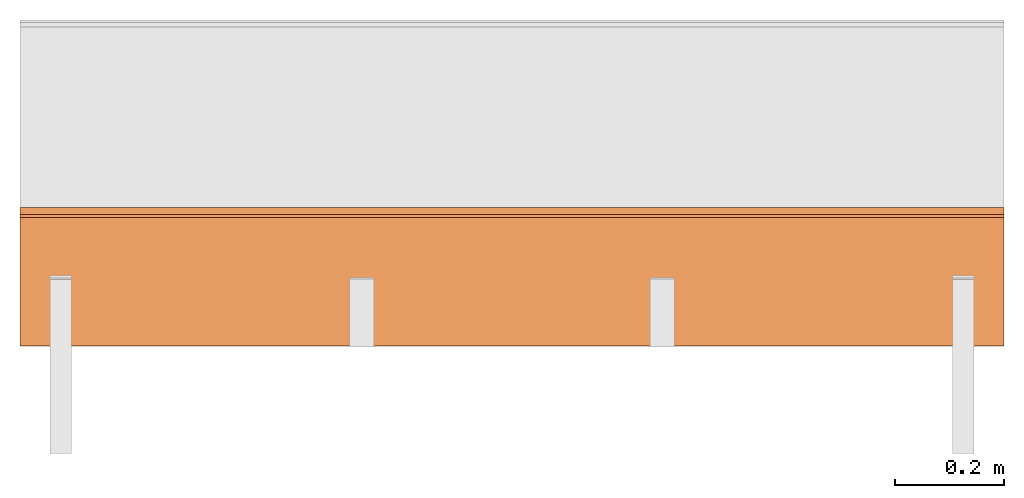
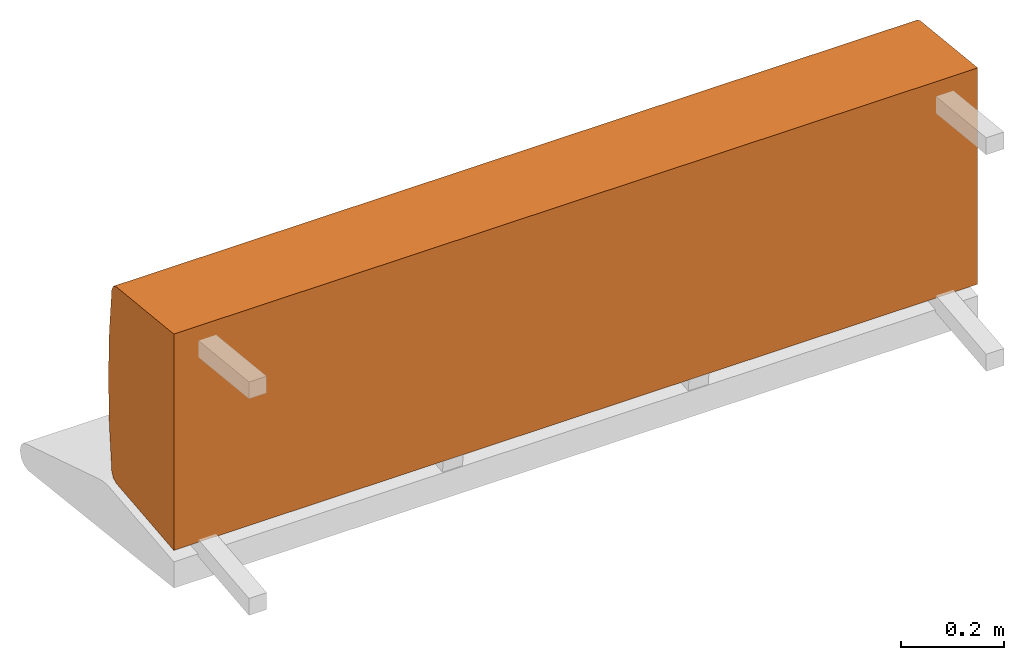
# One storey, part 1 of 3: 1 proxy, 1 element without a shape of its own.
"""IFC2X3 building model written with IfcOpenShell, lengths in metres."""

import ifcopenshell
import ifcopenshell.guid

model = None  # the IFC model being written
_history = None  # IfcOwnerHistory: only IFC2X3 demands one
_inside = {}  # id of a spatial element -> (the spatial element, [elements in it])
_under = {}  # id of a project, library or spatial element -> (it, [spatial elements below it])
_declared = {}  # id of a project -> (the project, [libraries it declares])
_typed = {}  # id of a type object -> (the type object, [elements of that type])
_made_of = {}  # id of a material, layer set ... -> (it, [elements and type objects made of it])


def new_model(schema):
    """Start an empty IFC model of exactly this schema.

    Asked for "IFC4X3", IfcOpenShell would pick the latest addendum, in which some entities
    have other attributes; the version numbers below select the first issue.
    IFC2X3 requires an IfcOwnerHistory on every rooted entity: one is made here for all.
    """
    global model, _history
    if schema == "IFC4X3":
        model = ifcopenshell.file(schema_version=(4, 3, 0, 0))
    else:
        model = ifcopenshell.file(schema=schema)
    _inside.clear()
    _under.clear()
    _declared.clear()
    _typed.clear()
    _made_of.clear()
    _history = None
    if model.schema == "IFC2X3":
        org = make("IfcOrganization", Name="unknown")
        user = make(
            "IfcPersonAndOrganization",
            ThePerson=make("IfcPerson", FamilyName="unknown"),
            TheOrganization=org,
        )
        app = make(
            "IfcApplication",
            ApplicationDeveloper=org,
            Version="unknown",
            ApplicationFullName="unknown",
            ApplicationIdentifier="unknown",
        )
        _history = make(
            "IfcOwnerHistory",
            OwningUser=user,
            OwningApplication=app,
            ChangeAction="ADDED",
            CreationDate=0,
        )
    return model


def make(cls, **values):
    """One entity of the class cls with the attributes given. An attribute that is None is left unset."""
    return model.create_entity(
        cls, **{name: value for name, value in values.items() if value is not None}
    )


def rooted(cls, **values):
    """An entity with a GlobalId (a new one), such as an element, a storey or a relation."""
    return make(cls, GlobalId=ifcopenshell.guid.new(), OwnerHistory=_history, **values)


def si_unit(unit_type, name, prefix=None):
    """IfcSIUnit, for example si_unit("LENGTHUNIT", "METRE", prefix="MILLI")."""
    return make("IfcSIUnit", UnitType=unit_type, Prefix=prefix, Name=name)


def assignment(units):
    """IfcUnitAssignment: the units of a project."""
    return None if units is None else make("IfcUnitAssignment", Units=units)


def point(xyz):
    """IfcCartesianPoint."""
    return None if xyz is None else make("IfcCartesianPoint", Coordinates=xyz)


def direction(xyz):
    """IfcDirection."""
    return None if xyz is None else make("IfcDirection", DirectionRatios=xyz)


def frame(location, z_axis=None, x_axis=None):
    """IfcAxis2Placement3D, a coordinate frame: its origin and axes. An axis left out is left unset."""
    return make(
        "IfcAxis2Placement3D",
        Location=point(location),
        Axis=direction(z_axis),
        RefDirection=direction(x_axis),
    )


def origin_with_axes():
    """The frame at (0, 0, 0) with the z axis (0, 0, 1) and the x axis (1, 0, 0) written out."""
    return frame((0.0, 0.0, 0.0), z_axis=(0.0, 0.0, 1.0), x_axis=(1.0, 0.0, 0.0))


def place(relative_to, where):
    """IfcLocalPlacement: puts the frame where relative to a parent placement (None: the world)."""
    return make(
        "IfcLocalPlacement", PlacementRelTo=relative_to, RelativePlacement=where
    )


def context(
    kind, dimensions, precision=None, world=None, true_north=None, identifier=None
):
    """IfcGeometricRepresentationContext, for example the 3D "Model" context."""
    return make(
        "IfcGeometricRepresentationContext",
        ContextIdentifier=identifier,
        ContextType=kind,
        CoordinateSpaceDimension=dimensions,
        Precision=precision,
        WorldCoordinateSystem=world,
        TrueNorth=true_north,
    )


def project(units=None, contexts=None):
    """IfcProject with its units and contexts."""
    return rooted(
        "IfcProject",
        Name="project",
        RepresentationContexts=contexts,
        UnitsInContext=assignment(units),
    )


def spatial(cls, under=None, at=None, **own):
    """A site, building, storey or space (cls), placed at a placement, below another one or the project."""
    s = rooted(cls, ObjectPlacement=at, **own)
    if under is not None:
        _under.setdefault(under.id(), (under, []))[1].append(s)
    return s


def faces_of(points, faces, orient=None, outer=None):
    """IfcFace entities. A face is a list of loops; a loop is a list of indices into points, from 0.

    orient and outer hold one flag for each loop. By default every Orientation is true, the
    first loop of a face is its IfcFaceOuterBound and the others are IfcFaceBound.
    """
    made = []
    for i, loops in enumerate(faces):
        bounds = []
        for j, loop in enumerate(loops):
            is_outer = j == 0 if outer is None else outer[i][j]
            bounds.append(
                make(
                    "IfcFaceOuterBound" if is_outer else "IfcFaceBound",
                    Bound=make("IfcPolyLoop", Polygon=[points[k] for k in loop]),
                    Orientation=True if orient is None else orient[i][j],
                )
            )
        made.append(make("IfcFace", Bounds=bounds))
    return made


def faceted_brep(points, faces, orient=None, outer=None, voids=None):
    """IfcFacetedBrep: a solid bounded by flat faces; with voids (closed shells), ...WithVoids."""
    shared = [point(p) for p in points]
    hull = make("IfcClosedShell", CfsFaces=faces_of(shared, faces, orient, outer))
    if voids is None:
        return make("IfcFacetedBrep", Outer=hull)
    return make(
        "IfcFacetedBrepWithVoids",
        Outer=hull,
        Voids=[
            make(cls, CfsFaces=faces_of(shared, fs, o, b)) for cls, fs, o, b in voids
        ],
    )


def shape(context_of_items, identifier, shape_type, items):
    """IfcShapeRepresentation: the items that make up one representation, for example the "Body"."""
    return make(
        "IfcShapeRepresentation",
        ContextOfItems=context_of_items,
        RepresentationIdentifier=identifier,
        RepresentationType=shape_type,
        Items=items,
    )


def source(mapping_origin, context_of_items, identifier, shape_type, items):
    """IfcRepresentationMap: a shape defined once, which mapped items show again and again."""
    return make(
        "IfcRepresentationMap",
        MappingOrigin=mapping_origin,
        MappedRepresentation=shape(context_of_items, identifier, shape_type, items),
    )


def transform(
    local_origin,
    x_axis=None,
    y_axis=None,
    z_axis=None,
    scale=None,
    scale2=None,
    scale3=None,
    uniform=True,
):
    """IfcCartesianTransformationOperator3D, or its non-uniform kind. x_axis, y_axis, z_axis: its Axis1, 2, 3."""
    if uniform:
        return make(
            "IfcCartesianTransformationOperator3D",
            Axis1=direction(x_axis),
            Axis2=direction(y_axis),
            LocalOrigin=point(local_origin),
            Scale=scale,
            Axis3=direction(z_axis),
        )
    return make(
        "IfcCartesianTransformationOperator3DnonUniform",
        Axis1=direction(x_axis),
        Axis2=direction(y_axis),
        LocalOrigin=point(local_origin),
        Scale=scale,
        Axis3=direction(z_axis),
        Scale2=scale2,
        Scale3=scale3,
    )


def mapped(mapping_source, mapping_target):
    """IfcMappedItem: shows the shape of a source again, moved by a transform."""
    return make(
        "IfcMappedItem", MappingSource=mapping_source, MappingTarget=mapping_target
    )


def made_of(thing, what):
    """Note that an element or type object is made of a material, layer set ...; save() writes the relation."""
    if what is not None:
        _made_of.setdefault(what.id(), (what, []))[1].append(thing)
    return thing


def element(
    cls,
    number,
    at=None,
    inside=None,
    cuts=None,
    type_object=None,
    material=None,
    context=None,
    identifier="Body",
    shape_type=None,
    held_by="IfcProductDefinitionShape",
    body=None,
    shapes=None,
    **own,
):
    """One element of the class cls, such as IfcWall. Its Tag is "e" and its number.

    at: its placement. inside: the storey or other place that contains it. cuts: it is an
    opening in that element (IfcRelVoidsElement). A single representation is given by context,
    identifier, shape_type and body (its items); several are given by shapes. held_by: the class
    of the entity that holds the representations. save() writes the other relations.
    """
    e = rooted(cls, Tag="e%d" % number, ObjectPlacement=at, **own)
    if body is not None:
        shapes = [shape(context, identifier, shape_type, body)]
    if shapes is not None:
        e.Representation = make(held_by, Representations=shapes)
    if inside is not None:
        _inside.setdefault(inside.id(), (inside, []))[1].append(e)
    if cuts is not None:
        rooted(
            "IfcRelVoidsElement", RelatingBuildingElement=cuts, RelatedOpeningElement=e
        )
    if type_object is not None:
        _typed.setdefault(type_object.id(), (type_object, []))[1].append(e)
    return made_of(e, material)


def aggregate(whole, parts):
    """IfcRelAggregates: a whole, such as a stair, and the parts it consists of."""
    return rooted("IfcRelAggregates", RelatingObject=whole, RelatedObjects=parts)


def save(model, path):
    """Write the relations noted so far, then the file.

    IfcRelAggregates (storeys below a building ...), IfcRelContainedInSpatialStructure (elements
    in a storey), IfcRelDefinesByType, IfcRelAssociatesMaterial and IfcRelDeclares: one each for
    every whole, place, type object, material and project.
    """
    for whole, parts in _under.values():
        aggregate(whole, parts)
    for where, things in _inside.values():
        rooted(
            "IfcRelContainedInSpatialStructure",
            RelatedElements=things,
            RelatingStructure=where,
        )
    for kind, things in _typed.values():
        rooted("IfcRelDefinesByType", RelatedObjects=things, RelatingType=kind)
    for what, things in _made_of.values():
        rooted("IfcRelAssociatesMaterial", RelatedObjects=things, RelatingMaterial=what)
    for by, libraries in _declared.values():
        rooted("IfcRelDeclares", RelatingContext=by, RelatedDefinitions=libraries)
    model.write(path)


model = new_model("IFC2X3")

# Units and contexts
model_context = context("Model", 3, precision=1e-06, world=origin_with_axes(), true_north=direction((0.0, 1.0, 0.0)))
ifc_project = project(units=[si_unit("LENGTHUNIT", "METRE"), si_unit("AREAUNIT", "SQUARE_METRE"), si_unit("VOLUMEUNIT", "CUBIC_METRE")], contexts=[model_context])

# Site, building, storey
site_placement = place(None, origin_with_axes())
site = spatial("IfcSite", under=ifc_project, at=site_placement, CompositionType="ELEMENT")
building_placement = place(site_placement, origin_with_axes())
building = spatial("IfcBuilding", under=site, at=building_placement, Name="Default Building", CompositionType="ELEMENT")
storey_placement = place(building_placement, origin_with_axes())
storey = spatial("IfcBuildingStorey", under=building, at=storey_placement, Name="Default Storey", CompositionType="ELEMENT", Elevation=0.0)

# Assembly, proxy
assembly_placement = place(storey_placement, origin_with_axes())
assembly = element("IfcElementAssembly", 1, at=assembly_placement, inside=storey, AssemblyPlace="NOTDEFINED", PredefinedType="NOTDEFINED")
shared_shape = source(origin_with_axes(), model_context, "Body", "Brep", [
    faceted_brep([(0.9049999713897705, -0.11101193726062775, -0.2574460208415985), (0.9049999713897705, -0.11100000143051147, 0.25755399465560913), (-0.9049999713897705, -0.11101193726062775, -0.2574460208415985), (-0.9049999713897705, -0.11101193726062775, -0.2574460208415985), (0.9049999713897705, -0.11100000143051147, 0.25755399465560913), (-0.9049999713897705, -0.11100000143051147, 0.25755399465560913), (0.9049999713897705, 0.11315424740314484, -0.23389045894145966), (0.9049999713897705, -0.11101193726062775, -0.2574460208415985), (-0.9049999713897705, 0.11315424740314484, -0.23389045894145966), (-0.9049999713897705, 0.11315424740314484, -0.23389045894145966), (0.9049999713897705, -0.11101193726062775, -0.2574460208415985), (-0.9049999713897705, -0.11101193726062775, -0.2574460208415985), (0.9049999713897705, 0.12509645521640778, -0.22825108468532562), (0.9049999713897705, 0.11315424740314484, -0.23389045894145966), (-0.9049999713897705, 0.12509645521640778, -0.22825108468532562), (-0.9049999713897705, 0.12509645521640778, -0.22825108468532562), (0.9049999713897705, 0.11315424740314484, -0.23389045894145966), (-0.9049999713897705, 0.11315424740314484, -0.23389045894145966), (0.9049999713897705, 0.1309199035167694, -0.21639753878116608), (0.9049999713897705, 0.12509645521640778, -0.22825108468532562), (-0.9049999713897705, 0.1309199035167694, -0.21639753878116608), (-0.9049999713897705, 0.1309199035167694, -0.21639753878116608), (0.9049999713897705, 0.12509645521640778, -0.22825108468532562), (-0.9049999713897705, 0.12509645521640778, -0.22825108468532562), (0.9049999713897705, 0.1406860649585724, -0.10837232321500778), (0.9049999713897705, 0.1309199035167694, -0.21639753878116608), (-0.9049999713897705, 0.1406860649585724, -0.10837232321500778), (-0.9049999713897705, 0.1406860649585724, -0.10837232321500778), (0.9049999713897705, 0.1309199035167694, -0.21639753878116608), (-0.9049999713897705, 0.1309199035167694, -0.21639753878116608), (0.9049999713897705, 0.1439555585384369, 4.417426316649653e-05), (0.9049999713897705, 0.1406860649585724, -0.10837232321500778), (-0.9049999713897705, 0.1439555585384369, 4.417426316649653e-05), (-0.9049999713897705, 0.1439555585384369, 4.417426316649653e-05), (0.9049999713897705, 0.1406860649585724, -0.10837232321500778), (-0.9049999713897705, 0.1406860649585724, -0.10837232321500778), (0.9049999713897705, 0.14071664214134216, 0.10846158862113953), (0.9049999713897705, 0.1439555585384369, 4.417426316649653e-05), (-0.9049999713897705, 0.14071664214134216, 0.10846158862113953), (-0.9049999713897705, 0.14071664214134216, 0.10846158862113953), (0.9049999713897705, 0.1439555585384369, 4.417426316649653e-05), (-0.9049999713897705, 0.1439555585384369, 4.417426316649653e-05), (0.9049999713897705, 0.1309809684753418, 0.21648956835269928), (0.9049999713897705, 0.14071664214134216, 0.10846158862113953), (-0.9049999713897705, 0.1309809684753418, 0.21648956835269928), (-0.9049999713897705, 0.1309809684753418, 0.21648956835269928), (0.9049999713897705, 0.14071664214134216, 0.10846158862113953), (-0.9049999713897705, 0.14071664214134216, 0.10846158862113953), (0.9049999713897705, 0.12515902519226074, 0.2283465564250946), (0.9049999713897705, 0.1309809684753418, 0.21648956835269928), (-0.9049999713897705, 0.12515902519226074, 0.2283465564250946), (-0.9049999713897705, 0.12515902519226074, 0.2283465564250946), (0.9049999713897705, 0.1309809684753418, 0.21648956835269928), (-0.9049999713897705, 0.1309809684753418, 0.21648956835269928), (0.9049999713897705, 0.11321509629487991, 0.23398803174495697), (0.9049999713897705, 0.12515902519226074, 0.2283465564250946), (-0.9049999713897705, 0.11321509629487991, 0.23398803174495697), (-0.9049999713897705, 0.11321509629487991, 0.23398803174495697), (0.9049999713897705, 0.12515902519226074, 0.2283465564250946), (-0.9049999713897705, 0.12515902519226074, 0.2283465564250946), (0.9049999713897705, -0.11100000143051147, 0.25755399465560913), (0.9049999713897705, 0.11321509629487991, 0.23398803174495697), (-0.9049999713897705, -0.11100000143051147, 0.25755399465560913), (-0.9049999713897705, -0.11100000143051147, 0.25755399465560913), (0.9049999713897705, 0.11321509629487991, 0.23398803174495697), (-0.9049999713897705, 0.11321509629487991, 0.23398803174495697), (0.9049999713897705, 0.1309809684753418, 0.21648956835269928), (0.9049999713897705, 0.12515902519226074, 0.2283465564250946), (0.9049999713897705, 0.14071664214134216, 0.10846158862113953), (0.9049999713897705, 0.14071664214134216, 0.10846158862113953), (0.9049999713897705, 0.12515902519226074, 0.2283465564250946), (0.9049999713897705, 0.11321509629487991, 0.23398803174495697), (0.9049999713897705, 0.14071664214134216, 0.10846158862113953), (0.9049999713897705, 0.11321509629487991, 0.23398803174495697), (0.9049999713897705, -0.11100000143051147, 0.25755399465560913), (0.9049999713897705, 0.12509645521640778, -0.22825108468532562), (0.9049999713897705, 0.1309199035167694, -0.21639753878116608), (0.9049999713897705, 0.11315424740314484, -0.23389045894145966), (0.9049999713897705, 0.11315424740314484, -0.23389045894145966), (0.9049999713897705, 0.1309199035167694, -0.21639753878116608), (0.9049999713897705, 0.1406860649585724, -0.10837232321500778), (0.9049999713897705, 0.11315424740314484, -0.23389045894145966), (0.9049999713897705, 0.1406860649585724, -0.10837232321500778), (0.9049999713897705, -0.11101193726062775, -0.2574460208415985), (0.9049999713897705, -0.11101193726062775, -0.2574460208415985), (0.9049999713897705, 0.1406860649585724, -0.10837232321500778), (0.9049999713897705, -0.11100000143051147, 0.25755399465560913), (0.9049999713897705, -0.11100000143051147, 0.25755399465560913), (0.9049999713897705, 0.1406860649585724, -0.10837232321500778), (0.9049999713897705, 0.1439555585384369, 4.417426316649653e-05), (0.9049999713897705, -0.11100000143051147, 0.25755399465560913), (0.9049999713897705, 0.1439555585384369, 4.417426316649653e-05), (0.9049999713897705, 0.14071664214134216, 0.10846158862113953), (-0.9049999713897705, 0.1406860649585724, -0.10837232321500778), (-0.9049999713897705, 0.1309199035167694, -0.21639753878116608), (-0.9049999713897705, 0.12509645521640778, -0.22825108468532562), (-0.9049999713897705, 0.12515902519226074, 0.2283465564250946), (-0.9049999713897705, 0.1309809684753418, 0.21648956835269928), (-0.9049999713897705, 0.11321509629487991, 0.23398803174495697), (-0.9049999713897705, 0.11321509629487991, 0.23398803174495697), (-0.9049999713897705, 0.1309809684753418, 0.21648956835269928), (-0.9049999713897705, 0.14071664214134216, 0.10846158862113953), (-0.9049999713897705, 0.11321509629487991, 0.23398803174495697), (-0.9049999713897705, 0.14071664214134216, 0.10846158862113953), (-0.9049999713897705, -0.11100000143051147, 0.25755399465560913), (-0.9049999713897705, -0.11100000143051147, 0.25755399465560913), (-0.9049999713897705, 0.14071664214134216, 0.10846158862113953), (-0.9049999713897705, 0.1439555585384369, 4.417426316649653e-05), (-0.9049999713897705, -0.11100000143051147, 0.25755399465560913), (-0.9049999713897705, 0.1439555585384369, 4.417426316649653e-05), (-0.9049999713897705, -0.11101193726062775, -0.2574460208415985), (-0.9049999713897705, -0.11101193726062775, -0.2574460208415985), (-0.9049999713897705, 0.1439555585384369, 4.417426316649653e-05), (-0.9049999713897705, 0.1406860649585724, -0.10837232321500778), (-0.9049999713897705, -0.11101193726062775, -0.2574460208415985), (-0.9049999713897705, 0.1406860649585724, -0.10837232321500778), (-0.9049999713897705, 0.11315424740314484, -0.23389045894145966), (-0.9049999713897705, 0.11315424740314484, -0.23389045894145966), (-0.9049999713897705, 0.1406860649585724, -0.10837232321500778), (-0.9049999713897705, 0.12509645521640778, -0.22825108468532562)], [[[0, 1, 2]], [[3, 4, 5]], [[6, 7, 8]], [[9, 10, 11]], [[12, 13, 14]], [[15, 16, 17]], [[18, 19, 20]], [[21, 22, 23]], [[24, 25, 26]], [[27, 28, 29]], [[30, 31, 32]], [[33, 34, 35]], [[36, 37, 38]], [[39, 40, 41]], [[42, 43, 44]], [[45, 46, 47]], [[48, 49, 50]], [[51, 52, 53]], [[54, 55, 56]], [[57, 58, 59]], [[60, 61, 62]], [[63, 64, 65]], [[66, 67, 68]], [[69, 70, 71]], [[72, 73, 74]], [[75, 76, 77]], [[78, 79, 80]], [[81, 82, 83]], [[84, 85, 86]], [[87, 88, 89]], [[90, 91, 92]], [[93, 94, 95]], [[96, 97, 98]], [[99, 100, 101]], [[102, 103, 104]], [[105, 106, 107]], [[108, 109, 110]], [[111, 112, 113]], [[114, 115, 116]], [[117, 118, 119]]]),
])
proxy_placement = place(assembly_placement, origin_with_axes())
proxy = element("IfcBuildingElementProxy", 2, at=proxy_placement, Name="1", ObjectType="1", CompositionType="ELEMENT", context=model_context, shape_type="MappedRepresentation", body=[
    mapped(shared_shape, transform((0.0, 0.0, 0.0), scale=1.0)),
])
aggregate(assembly, [proxy])

save(model, "model.ifc")
